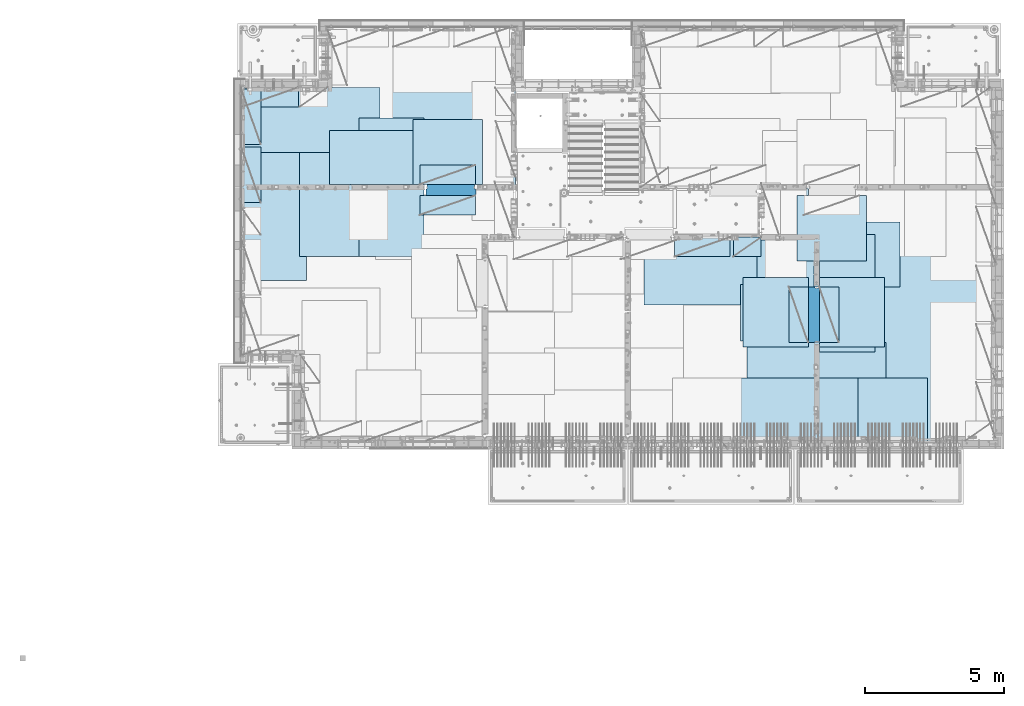
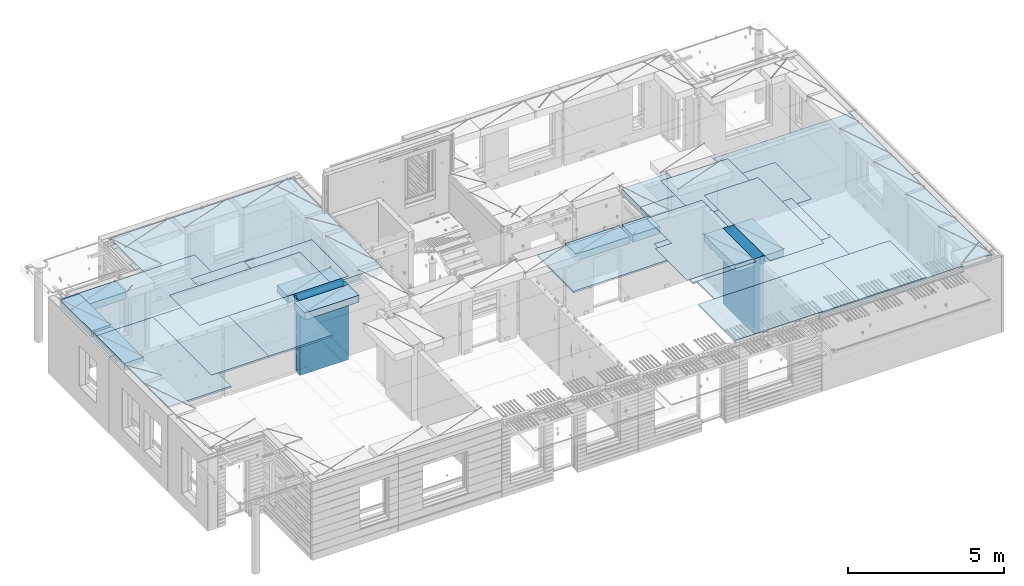
# One storey, part 205 of 350: 27 plates, 2 slabs, 25 elements without a shape of their own.
"""IFC2X3 building model written with IfcOpenShell, lengths in millimetres."""

from ifc_helpers import new_model, si_unit, frame, origin_with_axes, place, context, subcontext, project, spatial, faceted_brep, material, type_object, element, aggregate, save


model = new_model("IFC2X3")

# Units and contexts
model_context = context("Model", 3, precision=1e-05, world=origin_with_axes())
body_context = subcontext(model_context, "Body", "Model", "MODEL_VIEW")
ifc_project = project(units=[si_unit("LENGTHUNIT", "METRE", prefix="MILLI"), si_unit("AREAUNIT", "SQUARE_METRE"), si_unit("VOLUMEUNIT", "CUBIC_METRE"), si_unit("MASSUNIT", "GRAM", prefix="KILO"), si_unit("TIMEUNIT", "SECOND"), si_unit("PLANEANGLEUNIT", "RADIAN"), si_unit("SOLIDANGLEUNIT", "STERADIAN"), si_unit("THERMODYNAMICTEMPERATUREUNIT", "DEGREE_CELSIUS"), si_unit("LUMINOUSINTENSITYUNIT", "LUMEN")], contexts=[model_context])

# Site, building, storey
site_placement = place(None, origin_with_axes())
site = spatial("IfcSite", under=ifc_project, at=site_placement, CompositionType="ELEMENT")
building_placement = place(site_placement, origin_with_axes())
building = spatial("IfcBuilding", under=site, at=building_placement, CompositionType="ELEMENT")
storey_placement = place(building_placement, origin_with_axes())
storey = spatial("IfcBuildingStorey", under=building, at=storey_placement, Name="2", CompositionType="ELEMENT", Elevation=0.0)

# Assembly, slabs
assembly_1_placement = place(storey_placement, origin_with_axes())
assembly_1 = element("IfcElementAssembly", 1, at=assembly_1_placement, inside=storey, AssemblyPlace="NOTDEFINED", PredefinedType="REINFORCEMENT_UNIT")
ifc_material_1 = material(Name="CONCRETE/C30/37")
slab_type_1 = type_object("IfcSlabType", PredefinedType="NOTDEFINED")
slab_1_placement = place(assembly_1_placement, frame((7880.0, 16980.0, 87595.0), z_axis=(0.0, 1.0, 0.0), x_axis=(1.0, 0.0, 0.0)))
slab_1 = element("IfcSlab", 2, at=slab_1_placement, type_object=slab_type_1, material=ifc_material_1, PredefinedType="FLOOR", context=body_context, shape_type="Brep", body=[
    faceted_brep([(6583.68914550781, -135.0, 0.0), (6583.68914550781, 135.0, 0.0), (6583.68914550781, 135.0, 100.0), (6583.68914550781, -135.0, 100.0), (6649.99914550781, -135.0, 99.9997787475586), (6649.99914550781, 135.0, 99.9997787475586), (1.81898940354586e-12, -135.0, 1.81898940354586e-12), (-0.0001220703125, -135.0, 3600.0), (-0.0001220703125, 135.0, 3600.0), (1.81898940354586e-12, 135.0, 1.81898940354586e-12), (3110.00024414063, -135.0, 3600.0), (3110.00024414063, 135.0, 3600.0), (3110.00024414063, -135.0, 5760.0), (3110.00024414063, 135.0, 5760.0), (9850.0009765625, -135.0, 5760.0), (9850.0009765625, 135.0, 5760.0), (9850.0009765625, -135.0, 3600.0), (9850.0009765625, 135.0, 3600.0), (9870.0, -135.0, 3600.0), (9870.0, 135.0, 3600.0), (9870.0, -135.0, 0.0), (9870.0, 135.0, 0.0), (8449.99914550781, -135.0, 0.0), (8449.99914550781, 135.0, 0.0), (8449.99914550781, -135.0, 99.9997787475586), (8449.99914550781, 135.0, 99.9997787475586), (8283.68914550781, -135.0, 99.9997787475586), (8283.68914550781, 135.0, 99.9997787475586)], [[[0, 1, 2, 3]], [[4, 3, 2, 5]], [[6, 7, 8, 9]], [[7, 10, 11, 8]], [[10, 12, 13, 11]], [[12, 14, 15, 13]], [[14, 16, 17, 15]], [[16, 18, 19, 17]], [[18, 20, 21, 19]], [[21, 20, 22, 23]], [[24, 25, 23, 22]], [[26, 4, 5, 27, 25, 24]], [[1, 9, 8, 11, 13, 15, 17, 19, 21, 23, 25, 27, 5, 2]], [[6, 9, 1, 0]], [[26, 24, 22, 20, 18, 16, 14, 12, 10, 7, 6, 0, 3, 4]]]),
])
slab_type_2 = type_object("IfcSlabType", PredefinedType="NOTDEFINED")
slab_2_placement = place(assembly_1_placement, frame((28610.0, 7708.0, 87595.0), z_axis=(0.0, 1.0, 0.0), x_axis=(1.0, 0.0, 0.0)))
slab_2 = element("IfcSlab", 3, at=slab_2_placement, type_object=slab_type_2, material=ifc_material_1, PredefinedType="FLOOR", context=body_context, shape_type="Brep", body=[
    faceted_brep([(0.0, -135.0, 7430.0), (0.0, 135.0, 7430.0), (0.0, 135.0, 5722.0), (0.0, -135.0, 5722.0), (-1999.99938964844, -135.0, 7430.0), (-1999.99938964844, 135.0, 7430.0), (-1999.99938964844, -135.0, 9230.0), (-1999.99938964844, 135.0, 9230.0), (-300.000239723071, -135.0, 9230.0), (-300.000239723071, 135.0, 9230.0), (-300.00008947117, -135.0, 8972.00002930513), (-300.00008947117, 135.0, 8972.00002930513), (1385.00027673977, -135.0, 8972.00002930513), (1400.0006429507, -135.0, 8972.00002930513), (1400.0006429507, 135.0, 8972.00002930513), (1385.00027673977, 135.0, 8972.00002930513), (1400.0006429507, -135.0, 9230.0), (1400.0006429507, 135.0, 9230.0), (6449.99951171875, -135.0, 9230.0), (6449.99951171875, 135.0, 9230.0), (6449.99951171875, -135.0, 100.00023651123), (6449.99951171875, 135.0, 100.00023651123), (5318.0, -135.0, 100.0), (5318.0, 135.0, 100.0), (5318.0, -135.0, -8.68840288603678e-09), (5318.0, 135.0, -8.68840288603678e-09), (1.81898940354586e-12, -135.0, 1.81898940354586e-12), (1.81898940354586e-12, 135.0, 1.81898940354586e-12), (0.0, 135.0, 3679.99963378906), (100.00089263916, 135.0, 3679.99963378906), (100.00089263916, 135.0, 3822.0), (100.00089263916, 135.0, 5679.99963378906), (100.00089263916, 135.0, 5722.0), (100.00089263916, -135.0, 5722.0), (100.00089263916, -135.0, 3822.0), (100.00089263916, -135.0, 3679.99963378906), (0.0, -135.0, 3679.99963378906), (100.00089263916, -135.0, 5679.99963378906)], [[[0, 1, 2, 3]], [[0, 4, 5, 1]], [[4, 6, 7, 5]], [[7, 6, 8, 9]], [[8, 10, 11, 9]], [[12, 13, 14, 15, 11, 10]], [[16, 17, 14, 13]], [[18, 19, 17, 16]], [[18, 20, 21, 19]], [[20, 22, 23, 21]], [[22, 24, 25, 23]], [[24, 26, 27, 25]], [[1, 5, 7, 9, 11, 15, 14, 17, 19, 21, 23, 25, 27, 28, 29, 30, 31, 32, 2]], [[3, 2, 32, 33]], [[34, 35, 36, 26, 24, 22, 20, 18, 16, 13, 12, 10, 8, 6, 4, 0, 3, 33, 37]], [[27, 26, 36, 28]], [[35, 29, 28, 36]], [[34, 37, 31, 30, 29, 35]], [[33, 32, 31, 37]]]),
])

# Assembly, plate
assembly_2_placement = place(storey_placement, origin_with_axes())
assembly_2 = element("IfcElementAssembly", 4, at=assembly_2_placement, inside=storey, Name="Steel Assembly", AssemblyPlace="NOTDEFINED", PredefinedType="NOTDEFINED")
ifc_material_2 = material()
plate_type_1 = type_object("IfcPlateType", PredefinedType="NOTDEFINED")
plate_1_placement = place(assembly_2_placement, frame((27902.5000293051, 16680.0, 87695.1), z_axis=(1.0, 0.0, 0.0), x_axis=(0.0, -1.0, 0.0)))
plate_1 = element("IfcPlate", 5, at=plate_1_placement, type_object=plate_type_1, material=ifc_material_2, Name="1/2", context=body_context, shape_type="Brep", body=[
    faceted_brep([(0.0, -35.0, 0.0), (0.0, -35.0, 2500.0), (0.0, 35.0, 2500.0), (0.0, 35.0, 0.0), (2349.99951171875, -35.0, 2500.0), (2349.99951171875, 35.0, 2500.0), (2350.0, -35.0, 0.0), (2350.0, 35.0, 0.0)], [[[0, 1, 2, 3]], [[1, 4, 5, 2]], [[4, 6, 7, 5]], [[6, 0, 3, 7]], [[5, 7, 3, 2]], [[6, 4, 1, 0]]]),
])
aggregate(assembly_2, [plate_1])

assembly_3_placement = place(storey_placement, origin_with_axes())
assembly_3 = element("IfcElementAssembly", 6, at=assembly_3_placement, inside=storey, Name="Steel Assembly", AssemblyPlace="NOTDEFINED", PredefinedType="NOTDEFINED")
plate_2_placement = place(assembly_3_placement, frame((32610.0, 7750.0, 87695.1), z_axis=(-1.0, 3.00000001838171e-08, 0.0), x_axis=(0.0, 1.0, 0.0)))
plate_2 = element("IfcPlate", 7, at=plate_2_placement, type_object=plate_type_1, material=ifc_material_2, Name="1/2", context=body_context, shape_type="Brep", body=[
    faceted_brep([(0.0, -35.0, 0.0), (0.0, -35.0, 2500.0), (0.0, 35.0, 2500.0), (0.0, 35.0, 0.0), (2349.99951171875, -35.0, 2500.0), (2349.99951171875, 35.0, 2500.0), (2350.0, -35.0, 0.0), (2350.0, 35.0, 0.0)], [[[0, 1, 2, 3]], [[1, 4, 5, 2]], [[4, 6, 7, 5]], [[6, 0, 3, 7]], [[5, 7, 3, 2]], [[6, 4, 1, 0]]]),
])
aggregate(assembly_3, [plate_2])

assembly_4_placement = place(storey_placement, origin_with_axes())
assembly_4 = element("IfcElementAssembly", 8, at=assembly_4_placement, inside=storey, Name="Steel Assembly", AssemblyPlace="NOTDEFINED", PredefinedType="NOTDEFINED")
plate_3_placement = place(assembly_4_placement, frame((27395.0, 12730.0, 87695.1), z_axis=(-1.0, 3.00000001838171e-08, 0.0), x_axis=(0.0, 1.0, 0.0)))
plate_3 = element("IfcPlate", 9, at=plate_3_placement, type_object=plate_type_1, material=ifc_material_2, context=body_context, shape_type="Brep", body=[
    faceted_brep([(0.0, -35.0, 0.0), (0.0, -35.0, 5000.0), (0.0, 35.0, 5000.0), (0.0, 35.0, 0.0), (2349.99951171875, -35.0, 5000.0), (2349.99951171875, 35.0, 5000.0), (2350.0, -35.0, 0.0), (2350.0, 35.0, 0.0)], [[[0, 1, 2, 3]], [[1, 4, 5, 2]], [[4, 6, 7, 5]], [[6, 0, 3, 7]], [[5, 7, 3, 2]], [[6, 4, 1, 0]]]),
])
aggregate(assembly_4, [plate_3])

assembly_5_placement = place(storey_placement, origin_with_axes())
assembly_5 = element("IfcElementAssembly", 10, at=assembly_5_placement, inside=storey, Name="Steel Assembly", AssemblyPlace="NOTDEFINED", PredefinedType="NOTDEFINED")
plate_4_placement = place(assembly_5_placement, frame((28709.9995320312, 11230.0000289158, 87695.1), z_axis=(0.0, 1.0, 0.0), x_axis=(1.0, 0.0, 0.0)))
plate_4 = element("IfcPlate", 11, at=plate_4_placement, type_object=plate_type_1, material=ifc_material_2, Name="1/2", context=body_context, shape_type="Brep", body=[
    faceted_brep([(0.0, -35.0, 0.0), (0.0, -35.0, 2500.0), (0.0, 35.0, 2500.0), (0.0, 35.0, 0.0), (2349.99951171875, -35.0, 2500.0), (2349.99951171875, 35.0, 2500.0), (2350.0, -35.0, 0.0), (2350.0, 35.0, 0.0)], [[[0, 1, 2, 3]], [[1, 4, 5, 2]], [[4, 6, 7, 5]], [[6, 0, 3, 7]], [[5, 7, 3, 2]], [[6, 4, 1, 0]]]),
])
aggregate(assembly_5, [plate_4])

assembly_6_placement = place(storey_placement, origin_with_axes())
assembly_6 = element("IfcElementAssembly", 12, at=assembly_6_placement, inside=storey, Name="Steel Assembly", AssemblyPlace="NOTDEFINED", PredefinedType="NOTDEFINED")
plate_5_placement = place(assembly_6_placement, frame((25959.9995320312, 11230.0000289158, 87695.1), z_axis=(0.0, 1.0, 0.0), x_axis=(1.0, 0.0, 0.0)))
plate_5 = element("IfcPlate", 13, at=plate_5_placement, type_object=plate_type_1, material=ifc_material_2, Name="1/2", context=body_context, shape_type="Brep", body=[
    faceted_brep([(0.0, -35.0, 0.0), (0.0, -35.0, 2500.0), (0.0, 35.0, 2500.0), (0.0, 35.0, 0.0), (2349.99951171875, -35.0, 2500.0), (2349.99951171875, 35.0, 2500.0), (2350.0, -35.0, 0.0), (2350.0, 35.0, 0.0)], [[[0, 1, 2, 3]], [[1, 4, 5, 2]], [[4, 6, 7, 5]], [[6, 0, 3, 7]], [[5, 7, 3, 2]], [[6, 4, 1, 0]]]),
])
aggregate(assembly_6, [plate_5])

assembly_7_placement = place(storey_placement, origin_with_axes())
assembly_7 = element("IfcElementAssembly", 14, at=assembly_7_placement, inside=storey, Name="Steel Assembly", AssemblyPlace="NOTDEFINED", PredefinedType="NOTDEFINED")
plate_6_placement = place(assembly_7_placement, frame((7880.0, 20580.0, 87695.1), z_axis=(1.0, 0.0, 0.0), x_axis=(0.0, -1.0, 0.0)))
plate_6 = element("IfcPlate", 15, at=plate_6_placement, type_object=plate_type_1, material=ifc_material_2, context=body_context, shape_type="Brep", body=[
    faceted_brep([(0.0, -35.0, 0.0), (0.0, -35.0, 5000.0), (0.0, 35.0, 5000.0), (0.0, 35.0, 0.0), (2349.99951171875, -35.0, 5000.0), (2349.99951171875, 35.0, 5000.0), (2350.0, -35.0, 0.0), (2350.0, 35.0, 0.0)], [[[0, 1, 2, 3]], [[1, 4, 5, 2]], [[4, 6, 7, 5]], [[6, 0, 3, 7]], [[5, 7, 3, 2]], [[6, 4, 1, 0]]]),
])
aggregate(assembly_7, [plate_6])

assembly_8_placement = place(storey_placement, origin_with_axes())
assembly_8 = element("IfcElementAssembly", 16, at=assembly_8_placement, inside=storey, Name="Steel Assembly", AssemblyPlace="NOTDEFINED", PredefinedType="NOTDEFINED")
plate_7_placement = place(assembly_8_placement, frame((14063.69, 19430.0, 87695.1), z_axis=(1.0, 0.0, 0.0), x_axis=(0.0, -1.0, 0.0)))
plate_7 = element("IfcPlate", 17, at=plate_7_placement, type_object=plate_type_1, material=ifc_material_2, Name="1/2", context=body_context, shape_type="Brep", body=[
    faceted_brep([(0.0, -35.0, 0.0), (0.0, -35.0, 2500.0), (0.0, 35.0, 2500.0), (0.0, 35.0, 0.0), (2349.99951171875, -35.0, 2500.0), (2349.99951171875, 35.0, 2500.0), (2350.0, -35.0, 0.0), (2350.0, 35.0, 0.0)], [[[0, 1, 2, 3]], [[1, 4, 5, 2]], [[4, 6, 7, 5]], [[6, 0, 3, 7]], [[5, 7, 3, 2]], [[6, 4, 1, 0]]]),
])
aggregate(assembly_8, [plate_7])

assembly_9_placement = place(storey_placement, origin_with_axes())
assembly_9 = element("IfcElementAssembly", 18, at=assembly_9_placement, inside=storey, Name="Steel Assembly", AssemblyPlace="NOTDEFINED", PredefinedType="NOTDEFINED")
plate_8_placement = place(assembly_9_placement, frame((31610.0, 13388.0, 87695.1), z_axis=(-1.0, 3.00000001838171e-08, 0.0), x_axis=(0.0, 1.0, 0.0)))
plate_8 = element("IfcPlate", 19, at=plate_8_placement, type_object=plate_type_1, material=ifc_material_2, context=body_context, shape_type="Brep", body=[
    faceted_brep([(0.0, -35.0, 0.0), (0.0, -35.0, 5000.0), (0.0, 35.0, 5000.0), (0.0, 35.0, 0.0), (2349.99951171875, -35.0, 5000.0), (2349.99951171875, 35.0, 5000.0), (2350.0, -35.0, 0.0), (2350.0, 35.0, 0.0)], [[[0, 1, 2, 3]], [[1, 4, 5, 2]], [[4, 6, 7, 5]], [[6, 0, 3, 7]], [[5, 7, 3, 2]], [[6, 4, 1, 0]]]),
])
aggregate(assembly_9, [plate_8])

assembly_10_placement = place(storey_placement, origin_with_axes())
assembly_10 = element("IfcElementAssembly", 20, at=assembly_10_placement, inside=storey, Name="Steel Assembly", AssemblyPlace="NOTDEFINED", PredefinedType="NOTDEFINED")
plate_9_placement = place(assembly_10_placement, frame((31110.0, 9038.0, 87695.1), z_axis=(-1.0, 3.00000001838171e-08, 0.0), x_axis=(0.0, 1.0, 0.0)))
plate_9 = element("IfcPlate", 21, at=plate_9_placement, type_object=plate_type_1, material=ifc_material_2, context=body_context, shape_type="Brep", body=[
    faceted_brep([(0.0, -35.0, 0.0), (0.0, -35.0, 5000.0), (0.0, 35.0, 5000.0), (0.0, 35.0, 0.0), (2349.99951171875, -35.0, 5000.0), (2349.99951171875, 35.0, 5000.0), (2350.0, -35.0, 0.0), (2350.0, 35.0, 0.0)], [[[0, 1, 2, 3]], [[1, 4, 5, 2]], [[4, 6, 7, 5]], [[6, 0, 3, 7]], [[5, 7, 3, 2]], [[6, 4, 1, 0]]]),
])
aggregate(assembly_10, [plate_9])

assembly_11_placement = place(storey_placement, origin_with_axes())
assembly_11 = element("IfcElementAssembly", 22, at=assembly_11_placement, inside=storey, Name="Steel Assembly", AssemblyPlace="NOTDEFINED", PredefinedType="NOTDEFINED")
plate_10_placement = place(assembly_11_placement, frame((30510.0, 7750.0, 87695.1), z_axis=(-1.0, 3.00000001838171e-08, 0.0), x_axis=(0.0, 1.0, 0.0)))
plate_10 = element("IfcPlate", 23, at=plate_10_placement, type_object=plate_type_1, material=ifc_material_2, context=body_context, shape_type="Brep", body=[
    faceted_brep([(0.0, -35.0, 0.0), (0.0, -35.0, 5000.0), (0.0, 35.0, 5000.0), (0.0, 35.0, 0.0), (2349.99951171875, -35.0, 5000.0), (2349.99951171875, 35.0, 5000.0), (2350.0, -35.0, 0.0), (2350.0, 35.0, 0.0)], [[[0, 1, 2, 3]], [[1, 4, 5, 2]], [[4, 6, 7, 5]], [[6, 0, 3, 7]], [[5, 7, 3, 2]], [[6, 4, 1, 0]]]),
])
aggregate(assembly_11, [plate_10])

assembly_12_placement = place(storey_placement, origin_with_axes())
assembly_12 = element("IfcElementAssembly", 24, at=assembly_12_placement, inside=storey, Name="Steel Assembly", AssemblyPlace="NOTDEFINED", PredefinedType="NOTDEFINED")
plate_11_placement = place(assembly_12_placement, frame((10230.0, 18627.0, 87695.1), z_axis=(0.0, -1.0, 0.0), x_axis=(-1.0, 3.00000001838171e-08, 0.0)))
plate_11 = element("IfcPlate", 25, at=plate_11_placement, type_object=plate_type_1, material=ifc_material_2, context=body_context, shape_type="Brep", body=[
    faceted_brep([(0.0, -35.0, 0.0), (0.0, -35.0, 5000.0), (0.0, 35.0, 5000.0), (0.0, 35.0, 0.0), (2349.99951171875, -35.0, 5000.0), (2349.99951171875, 35.0, 5000.0), (2350.0, -35.0, 0.0), (2350.0, 35.0, 0.0)], [[[0, 1, 2, 3]], [[1, 4, 5, 2]], [[4, 6, 7, 5]], [[6, 0, 3, 7]], [[5, 7, 3, 2]], [[6, 4, 1, 0]]]),
])
aggregate(assembly_12, [plate_11])

assembly_13_placement = place(storey_placement, origin_with_axes())
assembly_13 = element("IfcElementAssembly", 26, at=assembly_13_placement, inside=storey, Name="Steel Assembly", AssemblyPlace="NOTDEFINED", PredefinedType="NOTDEFINED")
plate_12_placement = place(assembly_13_placement, frame((14463.69, 19480.0, 87695.1), z_axis=(0.0, -1.0, 0.0), x_axis=(-1.0, 3.00000001838171e-08, 0.0)))
plate_12 = element("IfcPlate", 27, at=plate_12_placement, type_object=plate_type_1, material=ifc_material_2, context=body_context, shape_type="Brep", body=[
    faceted_brep([(0.0, -35.0, 0.0), (0.0, -35.0, 5000.0), (0.0, 35.0, 5000.0), (0.0, 35.0, 0.0), (2349.99951171875, -35.0, 5000.0), (2349.99951171875, 35.0, 5000.0), (2350.0, -35.0, 0.0), (2350.0, 35.0, 0.0)], [[[0, 1, 2, 3]], [[1, 4, 5, 2]], [[4, 6, 7, 5]], [[6, 0, 3, 7]], [[5, 7, 3, 2]], [[6, 4, 1, 0]]]),
])
aggregate(assembly_13, [plate_12])

assembly_14_placement = place(storey_placement, origin_with_axes())
assembly_14 = element("IfcElementAssembly", 28, at=assembly_14_placement, inside=storey, Name="Steel Assembly", AssemblyPlace="NOTDEFINED", PredefinedType="NOTDEFINED")
plate_13_placement = place(assembly_14_placement, frame((12330.0, 19480.0, 87695.1), z_axis=(0.0, -1.0, 0.0), x_axis=(-1.0, 3.00000001838171e-08, 0.0)))
plate_13 = element("IfcPlate", 29, at=plate_13_placement, type_object=plate_type_1, material=ifc_material_2, context=body_context, shape_type="Brep", body=[
    faceted_brep([(0.0, -35.0, 0.0), (0.0, -35.0, 5000.0), (0.0, 35.0, 5000.0), (0.0, 35.0, 0.0), (2349.99951171875, -35.0, 5000.0), (2349.99951171875, 35.0, 5000.0), (2350.0, -35.0, 0.0), (2350.0, 35.0, 0.0)], [[[0, 1, 2, 3]], [[1, 4, 5, 2]], [[4, 6, 7, 5]], [[6, 0, 3, 7]], [[5, 7, 3, 2]], [[6, 4, 1, 0]]]),
])
aggregate(assembly_14, [plate_13])

assembly_15_placement = place(storey_placement, origin_with_axes())
assembly_15 = element("IfcElementAssembly", 30, at=assembly_15_placement, inside=storey, Name="Steel Assembly", AssemblyPlace="NOTDEFINED", PredefinedType="NOTDEFINED")
plate_type_2 = type_object("IfcPlateType", PredefinedType="NOTDEFINED")
plate_14_placement = place(assembly_15_placement, frame((7879.99987792969, 20530.0, 87595.3), z_axis=(1.0, 0.0, 0.0), x_axis=(0.0, -1.0, 0.0)))
plate_14 = element("IfcPlate", 31, at=plate_14_placement, type_object=plate_type_2, material=ifc_material_2, Name="RE1", context=body_context, shape_type="Brep", body=[
    faceted_brep([(1.81898940354586e-12, -135.0, 1.81898940354586e-12), (0.0, -135.0, 699.999999999996), (0.0, 135.0, 699.999999999996), (1.81898940354586e-12, 135.0, 1.81898940354586e-12), (1999.99951171875, -135.0, 699.999999999993), (1999.99951171875, 135.0, 699.999999999993), (2000.0, -135.0, -3.63797880709171e-12), (2000.0, 135.0, -3.63797880709171e-12)], [[[0, 1, 2, 3]], [[1, 4, 5, 2]], [[4, 6, 7, 5]], [[6, 0, 3, 7]], [[5, 7, 3, 2]], [[6, 4, 1, 0]]]),
])
aggregate(assembly_15, [plate_14])

assembly_16_placement = place(storey_placement, origin_with_axes())
assembly_16 = element("IfcElementAssembly", 32, at=assembly_16_placement, inside=storey, Name="Steel Assembly", AssemblyPlace="NOTDEFINED", PredefinedType="NOTDEFINED")
plate_15_placement = place(assembly_16_placement, frame((28710.2298779297, 13388.0, 87595.3), z_axis=(1.0, 0.0, 0.0), x_axis=(0.0, -1.0, 0.0)))
plate_15 = element("IfcPlate", 33, at=plate_15_placement, type_object=plate_type_2, material=ifc_material_2, Name="RE1", context=body_context, shape_type="Brep", body=[
    faceted_brep([(1.81898940354586e-12, -135.0, 1.81898940354586e-12), (0.0, -135.0, 699.999999999996), (0.0, 135.0, 699.999999999996), (1.81898940354586e-12, 135.0, 1.81898940354586e-12), (1999.99951171875, -135.0, 699.999999999993), (1999.99951171875, 135.0, 699.999999999993), (2000.0, -135.0, -3.63797880709171e-12), (2000.0, 135.0, -3.63797880709171e-12)], [[[0, 1, 2, 3]], [[1, 4, 5, 2]], [[4, 6, 7, 5]], [[6, 0, 3, 7]], [[5, 7, 3, 2]], [[6, 4, 1, 0]]]),
])
aggregate(assembly_16, [plate_15])

assembly_17_placement = place(storey_placement, origin_with_axes())
assembly_17 = element("IfcElementAssembly", 34, at=assembly_17_placement, inside=storey, Name="Steel Assembly", AssemblyPlace="NOTDEFINED", PredefinedType="NOTDEFINED")
plate_16_placement = place(assembly_17_placement, frame((28310.0001220703, 11388.0, 87595.3), z_axis=(-1.0, 3.00000001838171e-08, 0.0), x_axis=(0.0, 1.0, 0.0)))
plate_16 = element("IfcPlate", 35, at=plate_16_placement, type_object=plate_type_2, material=ifc_material_2, Name="RE1", context=body_context, shape_type="Brep", body=[
    faceted_brep([(1.81898940354586e-12, -135.0, 1.81898940354586e-12), (0.0, -135.0, 699.999999999996), (0.0, 135.0, 699.999999999996), (1.81898940354586e-12, 135.0, 1.81898940354586e-12), (1999.99951171875, -135.0, 699.999999999993), (1999.99951171875, 135.0, 699.999999999993), (2000.0, -135.0, -3.63797880709171e-12), (2000.0, 135.0, -3.63797880709171e-12)], [[[0, 1, 2, 3]], [[1, 4, 5, 2]], [[4, 6, 7, 5]], [[6, 0, 3, 7]], [[5, 7, 3, 2]], [[6, 4, 1, 0]]]),
])
aggregate(assembly_17, [plate_16])

assembly_18_placement = place(storey_placement, origin_with_axes())
assembly_18 = element("IfcElementAssembly", 36, at=assembly_18_placement, inside=storey, Name="Steel Assembly", AssemblyPlace="NOTDEFINED", PredefinedType="NOTDEFINED")
plate_17_placement = place(assembly_18_placement, frame((14313.6908542386, 17080.0001036336, 87595.3), z_axis=(0.0, 1.0, 0.0), x_axis=(1.0, 0.0, 0.0)))
plate_17 = element("IfcPlate", 37, at=plate_17_placement, type_object=plate_type_2, material=ifc_material_2, Name="RE1", context=body_context, shape_type="Brep", body=[
    faceted_brep([(1.81898940354586e-12, -135.0, 1.81898940354586e-12), (0.0, -135.0, 699.999999999996), (0.0, 135.0, 699.999999999996), (1.81898940354586e-12, 135.0, 1.81898940354586e-12), (1999.99951171875, -135.0, 699.999999999993), (1999.99951171875, 135.0, 699.999999999993), (2000.0, -135.0, -3.63797880709171e-12), (2000.0, 135.0, -3.63797880709171e-12)], [[[0, 1, 2, 3]], [[1, 4, 5, 2]], [[4, 6, 7, 5]], [[6, 0, 3, 7]], [[5, 7, 3, 2]], [[6, 4, 1, 0]]]),
])
aggregate(assembly_18, [plate_17])

assembly_19_placement = place(storey_placement, origin_with_axes())
assembly_19 = element("IfcElementAssembly", 38, at=assembly_19_placement, inside=storey, Name="Steel Assembly", AssemblyPlace="NOTDEFINED", PredefinedType="NOTDEFINED")
plate_18_placement = place(assembly_19_placement, frame((16313.6891457614, 16679.9998963664, 87595.3), z_axis=(0.0, -1.0, 0.0), x_axis=(-1.0, 3.00000001838171e-08, 0.0)))
plate_18 = element("IfcPlate", 39, at=plate_18_placement, type_object=plate_type_2, material=ifc_material_2, Name="RE1", context=body_context, shape_type="Brep", body=[
    faceted_brep([(1.81898940354586e-12, -135.0, 1.81898940354586e-12), (0.0, -135.0, 699.999999999996), (0.0, 135.0, 699.999999999996), (1.81898940354586e-12, 135.0, 1.81898940354586e-12), (1999.99951171875, -135.0, 699.999999999993), (1999.99951171875, 135.0, 699.999999999993), (2000.0, -135.0, -3.63797880709171e-12), (2000.0, 135.0, -3.63797880709171e-12)], [[[0, 1, 2, 3]], [[1, 4, 5, 2]], [[4, 6, 7, 5]], [[6, 0, 3, 7]], [[5, 7, 3, 2]], [[6, 4, 1, 0]]]),
])
aggregate(assembly_19, [plate_18])

assembly_20_placement = place(storey_placement, origin_with_axes())
assembly_20 = element("IfcElementAssembly", 40, at=assembly_20_placement, inside=storey, Name="Steel Assembly", AssemblyPlace="NOTDEFINED", PredefinedType="NOTDEFINED")
plate_19_placement = place(assembly_20_placement, frame((25494.9991457614, 15179.9998963664, 87595.3), z_axis=(0.0, -1.0, 0.0), x_axis=(-1.0, 3.00000001838171e-08, 0.0)))
plate_19 = element("IfcPlate", 41, at=plate_19_placement, type_object=plate_type_2, material=ifc_material_2, Name="RE1", context=body_context, shape_type="Brep", body=[
    faceted_brep([(1.81898940354586e-12, -135.0, 1.81898940354586e-12), (0.0, -135.0, 699.999999999996), (0.0, 135.0, 699.999999999996), (1.81898940354586e-12, 135.0, 1.81898940354586e-12), (1999.99951171875, -135.0, 699.999999999993), (1999.99951171875, 135.0, 699.999999999993), (2000.0, -135.0, -3.63797880709171e-12), (2000.0, 135.0, -3.63797880709171e-12)], [[[0, 1, 2, 3]], [[1, 4, 5, 2]], [[4, 6, 7, 5]], [[6, 0, 3, 7]], [[5, 7, 3, 2]], [[6, 4, 1, 0]]]),
])
aggregate(assembly_20, [plate_19])

assembly_21_placement = place(storey_placement, origin_with_axes())
assembly_21 = element("IfcElementAssembly", 42, at=assembly_21_placement, inside=storey, Name="Steel Assembly", AssemblyPlace="NOTDEFINED", PredefinedType="NOTDEFINED")
plate_20_placement = place(assembly_21_placement, frame((26610.0, 15180.0000000707, 87595.3), z_axis=(0.0, -1.0, 0.0), x_axis=(-1.0, 3.00000001838171e-08, 0.0)))
plate_20 = element("IfcPlate", 43, at=plate_20_placement, type_object=plate_type_2, material=ifc_material_2, Name="RE1_1/2", context=body_context, shape_type="Brep", body=[
    faceted_brep([(1.81898940354586e-12, -135.0, 1.81898940354586e-12), (0.0, -135.0, 699.999999999996), (0.0, 135.0, 699.999999999996), (1.81898940354586e-12, 135.0, 1.81898940354586e-12), (999.99951171875, -135.0, 700.0), (999.99951171875, 135.0, 700.0), (1000.0, -135.0, 0.0), (1000.0, 135.0, 0.0)], [[[0, 1, 2, 3]], [[1, 4, 5, 2]], [[4, 6, 7, 5]], [[6, 0, 3, 7]], [[5, 7, 3, 2]], [[6, 4, 1, 0]]]),
])
aggregate(assembly_21, [plate_20])

assembly_22_placement = place(storey_placement, origin_with_axes())
assembly_22 = element("IfcElementAssembly", 44, at=assembly_22_placement, inside=storey, Name="Steel Assembly", AssemblyPlace="NOTDEFINED", PredefinedType="NOTDEFINED")
plate_21_placement = place(assembly_22_placement, frame((9935.0, 20580.0001220703, 87595.3), z_axis=(0.0, -1.0, 0.0), x_axis=(-1.0, 3.00000001838171e-08, 0.0)))
plate_21 = element("IfcPlate", 45, at=plate_21_placement, type_object=plate_type_2, material=ifc_material_2, Name="RE1", context=body_context, shape_type="Brep", body=[
    faceted_brep([(1.81898940354586e-12, -135.0, 1.81898940354586e-12), (0.0, -135.0, 699.999999999996), (0.0, 135.0, 699.999999999996), (1.81898940354586e-12, 135.0, 1.81898940354586e-12), (1999.99951171875, -135.0, 699.999999999993), (1999.99951171875, 135.0, 699.999999999993), (2000.0, -135.0, -3.63797880709171e-12), (2000.0, 135.0, -3.63797880709171e-12)], [[[0, 1, 2, 3]], [[1, 4, 5, 2]], [[4, 6, 7, 5]], [[6, 0, 3, 7]], [[5, 7, 3, 2]], [[6, 4, 1, 0]]]),
])
aggregate(assembly_22, [plate_21])

assembly_23_placement = place(storey_placement, origin_with_axes())
assembly_23 = element("IfcElementAssembly", 46, at=assembly_23_placement, inside=storey, Name="Steel Assembly", AssemblyPlace="NOTDEFINED", PredefinedType="NOTDEFINED")
plate_22_placement = place(assembly_23_placement, frame((7879.99987792969, 18430.0, 87595.3), z_axis=(1.0, 0.0, 0.0), x_axis=(0.0, -1.0, 0.0)))
plate_22 = element("IfcPlate", 47, at=plate_22_placement, type_object=plate_type_2, material=ifc_material_2, Name="RE1", context=body_context, shape_type="Brep", body=[
    faceted_brep([(1.81898940354586e-12, -135.0, 1.81898940354586e-12), (0.0, -135.0, 699.999999999996), (0.0, 135.0, 699.999999999996), (1.81898940354586e-12, 135.0, 1.81898940354586e-12), (1999.99951171875, -135.0, 699.999999999993), (1999.99951171875, 135.0, 699.999999999993), (2000.0, -135.0, -3.63797880709171e-12), (2000.0, 135.0, -3.63797880709171e-12)], [[[0, 1, 2, 3]], [[1, 4, 5, 2]], [[4, 6, 7, 5]], [[6, 0, 3, 7]], [[5, 7, 3, 2]], [[6, 4, 1, 0]]]),
])
aggregate(assembly_23, [plate_22])

# Plate
plate_type_3 = type_object("IfcPlateType", PredefinedType="NOTDEFINED")
plate_23_placement = place(assembly_1_placement, frame((11048.0003525539, 17079.9997757405, 87725.45), z_axis=(0.0, 1.0, 0.0), x_axis=(1.0, 0.0, 0.0)))
plate_23 = element("IfcPlate", 48, at=plate_23_placement, type_object=plate_type_3, material=ifc_material_2, context=body_context, shape_type="Brep", body=[
    faceted_brep([(0.0, -5.0, 0.0), (0.0, -5.0, 1939.99963378906), (0.0, 5.0, 1939.99963378906), (0.0, 5.0, 0.0), (4827.9990234375, -5.0, 1939.99963378906), (4827.9990234375, 5.0, 1939.99963378906), (4827.9990234375, -5.0, 0.0), (4827.9990234375, 5.0, 0.0)], [[[0, 1, 2, 3]], [[1, 4, 5, 2]], [[4, 6, 7, 5]], [[6, 0, 3, 7]], [[5, 7, 3, 2]], [[6, 4, 1, 0]]]),
])

plate_type_4 = type_object("IfcPlateType", PredefinedType="NOTDEFINED")
plate_24_placement = place(assembly_1_placement, frame((28710.0010086818, 11039.9998138874, 87725.45), z_axis=(0.0, 1.0, 0.0), x_axis=(1.0, 0.0, 0.0)))
plate_24 = element("IfcPlate", 49, at=plate_24_placement, type_object=plate_type_4, material=ifc_material_2, context=body_context, shape_type="Brep", body=[
    faceted_brep([(0.0, -5.0, 0.0), (-0.00100868183653802, -5.0, 4240.0), (-0.00100868183653802, 5.0, 4240.0), (0.0, 5.0, 0.0), (2000.0, -5.0, 4240.0), (2000.0, 5.0, 4240.0), (2000.0, -5.0, 0.0), (2000.0, 5.0, 0.0)], [[[0, 1, 2, 3]], [[1, 4, 5, 2]], [[4, 6, 7, 5]], [[6, 0, 3, 7]], [[5, 7, 3, 2]], [[6, 4, 1, 0]]]),
])

plate_type_5 = type_object("IfcPlateType", PredefinedType="NOTDEFINED")
plate_25_placement = place(assembly_1_placement, frame((25860.0006272121, 11525.9998749226, 87725.45), z_axis=(1.0, 0.0, 0.0), x_axis=(0.0, -1.0, 0.0)))
plate_25 = element("IfcPlate", 50, at=plate_25_placement, type_object=plate_type_5, material=ifc_material_2, context=body_context, shape_type="Brep", body=[
    faceted_brep([(92.0000076293945, -5.0, 2449.99937278789), (92.0000076293945, 5.0, 2449.99937278789), (-1861.99975886647, 5.0, 2449.99937278789), (-1861.99975886647, -5.0, 2449.99937278789), (-1861.99975886647, -5.0, 2649.99937278789), (-1861.99975886647, 5.0, 2649.99939842034), (92.0000076293945, -5.0, 0.0), (0.0, -5.0, 0.0), (0.0, 5.0, 0.0), (92.0000076293945, 5.0, 0.0), (-1954.00048828125, -5.0, 0.0), (-1954.00048828125, 5.0, 0.0), (-1954.00048828125, -5.0, 600.000366210938), (-1954.00048828125, 5.0, 600.000366210938), (-3554.0, -5.0, 600.000366210938), (-3554.0, 5.0, 600.000366210938), (-3554.0, -5.0, 2649.99951171875), (-3554.0, 5.0, 2649.99951171875)], [[[0, 1, 2, 3]], [[4, 3, 2, 5]], [[6, 7, 8, 9]], [[7, 10, 11, 8]], [[10, 12, 13, 11]], [[12, 14, 15, 13]], [[14, 16, 17, 15]], [[17, 16, 4, 5]], [[1, 9, 8, 11, 13, 15, 17, 5, 2]], [[6, 9, 1, 0]], [[16, 14, 12, 10, 7, 6, 0, 3, 4]]]),
])

aggregate(assembly_1, [plate_24, plate_25, plate_23, slab_2, slab_1])

# Assembly, plate
assembly_24_placement = place(storey_placement, origin_with_axes())
assembly_24 = element("IfcElementAssembly", 51, at=assembly_24_placement, inside=storey, Name="Steel Assembly", AssemblyPlace="NOTDEFINED", PredefinedType="NOTDEFINED")
ifc_material_3 = material()
plate_type_6 = type_object("IfcPlateType", PredefinedType="NOTDEFINED")
plate_26_placement = place(assembly_24_placement, frame((14530.0, 16680.0, 86255.6000003815), z_axis=(0.0, 1.0, 0.0), x_axis=(1.0, 0.0, 0.0)))
plate_26 = element("IfcPlate", 52, at=plate_26_placement, type_object=plate_type_6, material=ifc_material_3, context=body_context, shape_type="Brep", body=[
    faceted_brep([(1749.99914550781, -1475.0, 400.0), (1749.99914550781, -1475.0, 243.000000000004), (1749.99914550781, 1475.0, 243.000000000004), (1749.99914550781, 1475.0, 400.0), (1799.99914550781, -1475.0, 221.333333333332), (1799.99914550781, 1475.0, 221.333333333332), (30.0, -1475.0, 400.0), (30.0, 1475.0, 400.0), (30.0, 1475.0, 243.0), (30.0, -1475.0, 243.0), (0.0, 1475.0, 230.0), (0.0, -1475.0, 230.0), (0.0, 1475.0, 0.0), (0.0, -1475.0, 0.0), (1799.99914550781, -1475.0, 3.63797880709171e-12), (1799.99914550781, 1475.0, 3.63797880709171e-12)], [[[0, 1, 2, 3]], [[4, 5, 2, 1]], [[6, 7, 8, 9]], [[9, 8, 10, 11]], [[12, 13, 11, 10]], [[14, 13, 12, 15]], [[0, 6, 9, 11, 13, 14, 4, 1]], [[7, 6, 0, 3]], [[15, 12, 10, 8, 7, 3, 2, 5]], [[14, 15, 5, 4]]]),
])
aggregate(assembly_24, [plate_26])

assembly_25_placement = place(storey_placement, origin_with_axes())
assembly_25 = element("IfcElementAssembly", 53, at=assembly_25_placement, inside=storey, Name="Steel Assembly", AssemblyPlace="NOTDEFINED", PredefinedType="NOTDEFINED")
plate_27_placement = place(assembly_25_placement, frame((28710.0, 11388.0, 86255.6000003815), z_axis=(-1.0, 3.00000001838171e-08, 0.0), x_axis=(0.0, 1.0, 0.0)))
plate_27 = element("IfcPlate", 54, at=plate_27_placement, type_object=plate_type_6, material=ifc_material_3, context=body_context, shape_type="Brep", body=[
    faceted_brep([(0.0, -1475.0, 170.000000230655), (0.0, 1475.0, 170.000000368096), (30.0, 1475.0, 156.999999999998), (30.0, -1475.0, 156.999999999998), (29.9999998430139, -1475.0, 0.0), (29.9999998430139, 1475.0, 0.0), (0.0, -1475.0, 400.0), (1999.99963378906, -1475.0, 400.0), (1999.99963378906, 1475.0, 400.0), (0.0, 1475.0, 400.0), (1999.99963378906, -1475.0, 170.000003831468), (1999.99963378906, 1475.0, 170.000003831468), (1969.99962494722, -1475.0, 157.0), (1969.99962494722, 1475.0, 157.0), (1969.99962494722, -1475.0, 0.0), (1969.99962494722, 1475.0, 0.0)], [[[0, 1, 2, 3]], [[4, 3, 2, 5]], [[6, 7, 8, 9]], [[8, 7, 10, 11]], [[12, 13, 11, 10]], [[14, 15, 13, 12]], [[15, 14, 4, 5]], [[1, 9, 8, 11, 13, 15, 5, 2]], [[6, 9, 1, 0]], [[14, 12, 10, 7, 6, 0, 3, 4]]]),
])
aggregate(assembly_25, [plate_27])

save(model, "model.ifc")
